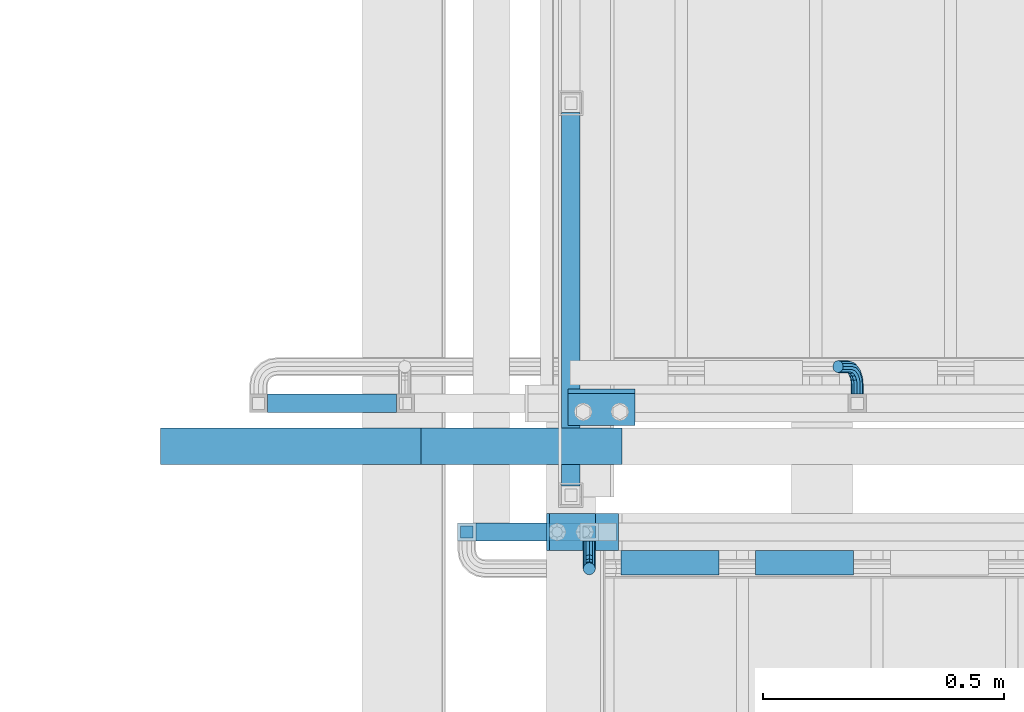
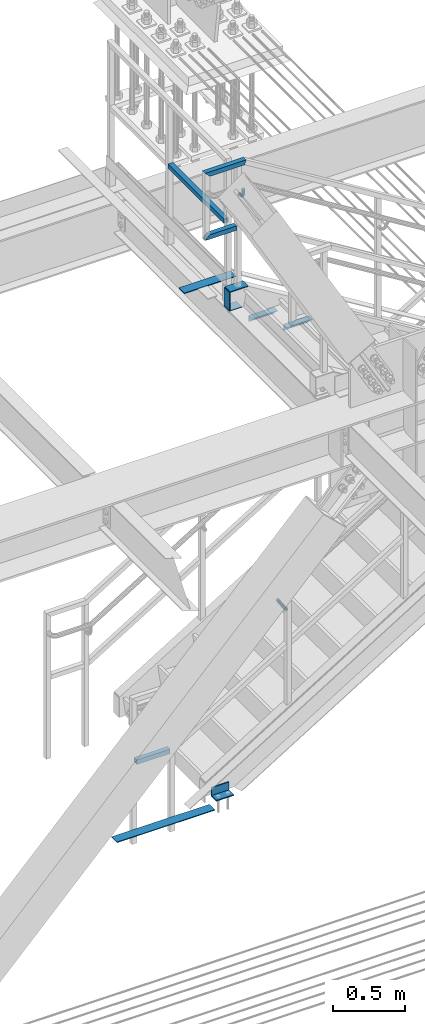
# One storey, part 2584 of 3843: 13 beams, 1 member, 7 elements without a shape of their own.
"""IFC2X3 building model written with IfcOpenShell, lengths in millimetres."""

from ifc_helpers import new_model, si_unit, frame, origin_with_axes, place, context, subcontext, project, spatial, faceted_brep, material, type_object, element, aggregate, save


model = new_model("IFC2X3")

# Units and contexts
model_context = context("Model", 3, precision=1e-05, world=origin_with_axes())
body_context = subcontext(model_context, "Body", "Model", "MODEL_VIEW")
ifc_project = project(units=[si_unit("LENGTHUNIT", "METRE", prefix="MILLI"), si_unit("AREAUNIT", "SQUARE_METRE"), si_unit("VOLUMEUNIT", "CUBIC_METRE"), si_unit("MASSUNIT", "GRAM", prefix="KILO"), si_unit("TIMEUNIT", "SECOND"), si_unit("PLANEANGLEUNIT", "RADIAN"), si_unit("SOLIDANGLEUNIT", "STERADIAN"), si_unit("THERMODYNAMICTEMPERATUREUNIT", "DEGREE_CELSIUS"), si_unit("LUMINOUSINTENSITYUNIT", "LUMEN")], contexts=[model_context])

# Site, building, storey
site_placement = place(None, origin_with_axes())
site = spatial("IfcSite", under=ifc_project, at=site_placement, CompositionType="ELEMENT")
building_placement = place(site_placement, origin_with_axes())
building = spatial("IfcBuilding", under=site, at=building_placement, Name="Undefined", CompositionType="ELEMENT")
storey_placement = place(building_placement, origin_with_axes())
storey = spatial("IfcBuildingStorey", under=building, at=storey_placement, Name="Undefined", CompositionType="ELEMENT", Elevation=0.0)

# Assembly, beam
assembly_1_placement = place(storey_placement, origin_with_axes())
assembly_1 = element("IfcElementAssembly", 1, at=assembly_1_placement, inside=storey, Name="STAIR", AssemblyPlace="NOTDEFINED", PredefinedType="RIGID_FRAME")
ifc_material_1 = material(Name="STEEL/A36")
beam_type_1 = type_object("IfcBeamType", Name="L3X3X3/8", PredefinedType="NOTDEFINED")
beam_1_placement = place(assembly_1_placement, frame((80943.4500000127, 16717.9625000001, 30518.1), z_axis=(0.0, -1.0, 0.0), x_axis=(-1.0, 0.0, 0.0)))
beam_1 = element("IfcBeam", 2, at=beam_1_placement, type_object=beam_type_1, material=ifc_material_1, Name="CLEAT", ObjectType="L3X3X3/8", context=body_context, shape_type="Brep", body=[
    faceted_brep([(0.0, 38.0999999999985, -38.0999999999985), (0.0, 38.0999999999985, 38.0999999999985), (139.699999999997, 38.0999999999985, 38.0999999999985), (139.699999999997, 38.0999999999985, -38.0999999999985), (0.0, 28.5750000000007, 38.0999999999985), (139.699999999997, 28.5750000000007, 38.0999999999985), (0.0, 28.5750000000007, -28.5750000000007), (139.699999999997, 28.5750000000007, -28.5750000000007), (0.0, -38.0999999999985, -28.5750000000007), (139.699999999997, -38.0999999999985, -28.5750000000007), (0.0, -38.0999999999985, -38.0999999999985), (139.699999999997, -38.0999999999985, -38.0999999999985)], [[[0, 1, 2, 3]], [[1, 4, 5, 2]], [[4, 6, 7, 5]], [[6, 8, 9, 7]], [[8, 10, 11, 9]], [[10, 0, 3, 11]], [[5, 7, 9, 11, 3, 2]], [[10, 8, 6, 4, 1, 0]]]),
])
aggregate(assembly_1, [beam_1])

# Assembly, beams
assembly_2_placement = place(storey_placement, origin_with_axes())
assembly_2 = element("IfcElementAssembly", 3, at=assembly_2_placement, inside=storey, Name="RAIL", AssemblyPlace="NOTDEFINED", PredefinedType="RIGID_FRAME")
ifc_material_2 = material()
beam_type_2 = type_object("IfcBeamType", Name="HSS1-1/2X1-1/2X1/4", PredefinedType="NOTDEFINED")
beam_2_placement = place(assembly_2_placement, frame((80829.1500007652, 16459.2, 35483.8), z_axis=(0.0, 0.0, 1.0), x_axis=(-1.0, 0.0, 0.0)))
beam_2 = element("IfcBeam", 4, at=beam_2_placement, type_object=beam_type_2, material=ifc_material_2, Name="RAIL", ObjectType="HSS1-1/2X1-1/2X1/4", context=body_context, shape_type="Brep", body=[
    faceted_brep([(0.0, 12.6999993299978, -12.6999993300014), (0.0, -12.6999993299978, -12.6999993300014), (247.650000111418, -12.6999993300014, -12.6999993299978), (247.650000111418, 12.6999993300014, -12.6999993299978), (0.0, -12.6999993299978, 12.6999993300014), (222.250001451423, -12.6999993300014, 12.6999993299978), (0.0, 12.6999993299978, 12.6999993300014), (222.250001451423, 12.6999993300014, 12.6999993299978), (0.0, 19.0500000000029, -19.0499999999993), (0.0, 19.0499992350015, 19.0499992350015), (215.900001546412, 19.0499992350015, 19.0499992350015), (254.000000016429, 19.0499992350015, -19.0499992350015), (0.0, -19.0499992350015, 19.0499992350015), (215.900001546412, -19.0499992350015, 19.0499992350015), (0.0, -19.0499992350015, -19.0499992350015), (254.000000016429, -19.0499992350015, -19.0499992350015)], [[[0, 1, 2, 3]], [[1, 4, 5, 2]], [[4, 6, 7, 5]], [[6, 0, 3, 7]], [[8, 9, 10, 11]], [[9, 12, 13, 10]], [[12, 14, 15, 13]], [[14, 8, 11, 15]], [[13, 15, 11, 10], [5, 7, 3, 2]], [[14, 12, 9, 8], [6, 4, 1, 0]]]),
])
beam_3_placement = place(assembly_2_placement, frame((80594.2000000002, 16459.2, 36017.2), z_axis=(0.0, 0.0, -1.0), x_axis=(1.0, 0.0, 0.0)))
beam_3 = element("IfcBeam", 5, at=beam_3_placement, type_object=beam_type_2, material=ifc_material_2, Name="RAIL", ObjectType="HSS1-1/2X1-1/2X1/4", context=body_context, shape_type="Brep", body=[
    faceted_brep([(-12.6999993309546, 12.6999993299978, -12.6999993299978), (-12.6999993309546, -12.6999993299978, -12.6999993299978), (308.394635558259, -12.6999993300014, -12.6999993299978), (308.394635558259, 12.6999993300014, -12.6999993299978), (12.6999993290483, -12.6999993299978, 12.6999993299978), (301.205364309426, -12.6999993300014, 12.6999993299978), (12.6999993290483, 12.6999993299978, 12.6999993299978), (301.205364309426, 12.6999993300014, 12.6999993299978), (-19.0499992359546, 19.0499992350015, -19.0499992350015), (19.0499992350015, 19.0499992350015, 19.0499992350015), (299.408046429278, 19.0499992350015, 19.0499992350015), (310.191953438392, 19.0499992350015, -19.0499992350015), (19.0499992350015, -19.0499992350015, 19.0499992350015), (299.408046429278, -19.0499992350015, 19.0499992350015), (-19.0499992359546, -19.0499992350015, -19.0499992350015), (310.191953438392, -19.0499992350015, -19.0499992350015)], [[[0, 1, 2, 3]], [[1, 4, 5, 2]], [[4, 6, 7, 5]], [[6, 0, 3, 7]], [[8, 9, 10, 11]], [[9, 12, 13, 10]], [[12, 14, 15, 13]], [[14, 8, 11, 15]], [[13, 15, 11, 10], [5, 7, 3, 2]], [[14, 12, 9, 8], [6, 4, 1, 0]]]),
])

# Assembly, beam
assembly_3_placement = place(storey_placement, origin_with_axes())
assembly_3 = element("IfcElementAssembly", 6, at=assembly_3_placement, inside=storey, Name="RAIL", AssemblyPlace="NOTDEFINED", PredefinedType="RIGID_FRAME")
beam_4_placement = place(assembly_3_placement, frame((80810.1, 17348.2, 35483.8), z_axis=(0.0, 0.0, 1.0), x_axis=(0.0, -1.0, 0.0)))
beam_4 = element("IfcBeam", 7, at=beam_4_placement, type_object=beam_type_2, material=ifc_material_2, Name="RAIL", ObjectType="HSS1-1/2X1-1/2X1/4", context=body_context, shape_type="Brep", body=[
    faceted_brep([(19.0499992350015, -19.0499992350015, -19.0499992350015), (19.0499992350015, -19.0499992350015, 19.0499992350015), (19.0499992350015, 19.0499992350015, 19.0499992350015), (19.0499992350015, 19.0499992350015, -19.0499992350015), (19.0499992350015, 12.6999993299978, 12.6999993299978), (19.0499992350015, -12.6999993299978, 12.6999993299978), (19.0499992350015, -12.6999993299978, -12.6999993299978), (19.0499992350015, 12.6999993299978, -12.6999993299978), (793.749999999996, 19.0499992349942, -19.0499992350015), (793.749999999996, -19.0499992349942, -19.0499992350015), (793.749999999996, -19.0499992349942, 19.0499992350015), (793.749999999996, 19.0499992349942, 19.0499992350015), (793.749999999996, -12.6999993299978, 12.6999993299978), (793.749999999996, 12.6999993299978, 12.6999993299978), (793.749999999996, 12.6999993299978, -12.6999993299978), (793.749999999996, -12.6999993299978, -12.6999993299978)], [[[0, 1, 2, 3], [4, 5, 6, 7]], [[8, 9, 0, 3]], [[9, 10, 1, 0]], [[10, 11, 2, 1]], [[11, 8, 3, 2]], [[10, 9, 8, 11], [12, 13, 14, 15]], [[13, 12, 5, 4]], [[14, 13, 4, 7]], [[15, 14, 7, 6]], [[12, 15, 6, 5]]]),
])
aggregate(assembly_3, [beam_4])

assembly_4_placement = place(storey_placement, origin_with_axes())
assembly_4 = element("IfcElementAssembly", 8, at=assembly_4_placement, inside=storey, Name="RAIL", AssemblyPlace="NOTDEFINED", PredefinedType="RIGID_FRAME")
beam_5_placement = place(assembly_4_placement, frame((80162.3999999997, 16725.9, 31013.3999999999), z_axis=(0.0, 0.0, 1.0), x_axis=(1.0, 0.0, 0.0)))
beam_5 = element("IfcBeam", 9, at=beam_5_placement, type_object=beam_type_2, material=ifc_material_2, Name="RAIL", ObjectType="HSS1-1/2X1-1/2X1/4", context=body_context, shape_type="Brep", body=[
    faceted_brep([(285.750000765285, -19.0499992350015, 19.0499992350015), (285.750000765285, -19.0499992350015, -19.0499992350015), (285.750000765285, 19.0499992350015, -19.0499992350015), (285.750000765285, 19.0499992350015, 19.0499992350015), (285.750000765009, -12.6999993300014, 12.6999993299978), (285.750000765009, 12.6999993300014, 12.6999993299978), (285.750000765009, 12.6999993300014, -12.6999993299978), (285.750000765009, -12.6999993300014, -12.6999993299978), (19.0499992350015, 19.0499992350015, -19.0499992350015), (19.0499992350015, 19.0499992350015, 19.0499992350015), (19.0499992350015, -19.0499992350015, 19.0499992350015), (19.0499992350015, -19.0499992350015, -19.0499992350015), (19.0499992350015, 12.6999993299978, 12.6999993299978), (19.0499992350015, -12.6999993299978, 12.6999993299978), (19.0499992350015, -12.6999993299978, -12.6999993299978), (19.0499992350015, 12.6999993299978, -12.6999993299978)], [[[0, 1, 2, 3], [4, 5, 6, 7]], [[8, 9, 3, 2]], [[9, 10, 0, 3]], [[10, 11, 1, 0]], [[11, 8, 2, 1]], [[11, 10, 9, 8], [12, 13, 14, 15]], [[14, 13, 4, 7]], [[15, 14, 7, 6]], [[12, 15, 6, 5]], [[13, 12, 5, 4]]]),
])

# Assembly, beams
assembly_5_placement = place(storey_placement, origin_with_axes())
assembly_5 = element("IfcElementAssembly", 10, at=assembly_5_placement, inside=storey, Name="STAIR", AssemblyPlace="NOTDEFINED", PredefinedType="RIGID_FRAME")
beam_type_3 = type_object("IfcBeamType", PredefinedType="NOTDEFINED")
beam_6_placement = place(assembly_5_placement, frame((80759.299999998, 16459.2000000053, 34813.875), z_axis=(0.0, 1.0, 0.0), x_axis=(1.0, 0.0, 0.0)))
beam_6 = element("IfcBeam", 11, at=beam_6_placement, type_object=beam_type_3, material=ifc_material_1, Name="PLATE", context=body_context, shape_type="Brep", body=[
    faceted_brep([(0.0, 3.17500000000291, -38.0999999999985), (0.0, 3.17500000000291, 38.0999999999985), (101.60000000002, 3.17500000000291, 38.0999999999985), (101.60000000002, 3.17500000000291, -38.0999999999985), (0.0, -3.17500000000291, 38.0999999999985), (101.60000000002, -3.17500000000291, 38.0999999999985), (0.0, -3.17500000000291, -38.0999999999985), (101.60000000002, -3.17500000000291, -38.0999999999985)], [[[0, 1, 2, 3]], [[1, 4, 5, 2]], [[4, 6, 7, 5]], [[6, 0, 3, 7]], [[5, 7, 3, 2]], [[6, 4, 1, 0]]]),
])
ifc_material_3 = material(Name="STEEL/A572-50")
beam_7_placement = place(assembly_5_placement, frame((80908.4302402225, 16459.1999999992, 34972.625), z_axis=(0.0, -1.0, 0.0), x_axis=(-1.0, 0.0, 0.0)))
beam_7 = element("IfcBeam", 12, at=beam_7_placement, type_object=beam_type_3, material=ifc_material_3, Name="PLATE", context=body_context, shape_type="Brep", body=[
    faceted_brep([(0.0, 3.17500000000291, -38.0999999999985), (0.0, 3.17500000000291, 38.0999999999985), (142.780240222812, 3.17500000000291, 38.1000000000004), (142.780240222812, 3.17500000000291, -38.1000000000004), (0.0, -3.17500000000291, 38.0999999999985), (142.780240222812, -3.17500000000291, 38.1000000000004), (0.0, -3.17500000000291, -38.0999999999985), (142.780240222812, -3.17500000000291, -38.1000000000004)], [[[0, 1, 2, 3]], [[1, 4, 5, 2]], [[4, 6, 7, 5]], [[6, 0, 3, 7]], [[5, 7, 3, 2]], [[6, 4, 1, 0]]]),
])
beam_8_placement = place(assembly_5_placement, frame((80762.475, 16459.2000000001, 34969.4500000002), z_axis=(0.0, -1.0, 0.0), x_axis=(0.0, 0.0, -1.0)))
beam_8 = element("IfcBeam", 13, at=beam_8_placement, type_object=beam_type_3, material=ifc_material_3, Name="PLATE", context=body_context, shape_type="Brep", body=[
    faceted_brep([(0.0, -3.17500000000291, -38.0999999999985), (0.0, -3.17500000000291, 38.0999999999985), (0.0, 3.17500000000291, 38.0999999999985), (0.0, 3.17500000000291, -38.0999999999985), (152.400000000009, -3.17500000000291, 38.0999999999985), (152.400000000009, 3.17500000000291, 38.0999999999985), (152.400000000009, 3.17500000000291, -38.0999999999985), (152.400000000009, -3.17500000000291, -38.0999999999985)], [[[0, 1, 2, 3]], [[2, 1, 4, 5]], [[3, 2, 5, 6]], [[0, 3, 6, 7]], [[1, 0, 7, 4]], [[4, 7, 6, 5]]]),
])

# Assembly, beam
assembly_6_placement = place(storey_placement, origin_with_axes())
assembly_6 = element("IfcElementAssembly", 14, at=assembly_6_placement, inside=storey, Name="ref.", AssemblyPlace="NOTDEFINED", PredefinedType="RIGID_FRAME")
ifc_material_4 = material(Name="STEEL/Steel_Undefined")
beam_9_placement = place(assembly_6_placement, frame((79959.2, 16637.0, 30476.825), z_axis=(0.0, 1.0, 0.0), x_axis=(1.0, 0.0, 0.0)))
beam_9 = element("IfcBeam", 15, at=beam_9_placement, type_object=beam_type_3, material=ifc_material_4, Name="ref.", context=body_context, shape_type="Brep", body=[
    faceted_brep([(0.0, 3.17500000000291, -38.0999999999985), (0.0, 3.17500000000291, 38.0999999999985), (787.400000000009, 3.17499999999927, 38.0999999999985), (787.400000000009, 3.17499999999927, -38.0999999999985), (0.0, -3.17500000000291, 38.0999999999985), (787.400000000009, -3.17499999999927, 38.0999999999985), (0.0, -3.17500000000291, -38.0999999999985), (787.400000000009, -3.17499999999927, -38.0999999999985)], [[[0, 1, 2, 3]], [[1, 4, 5, 2]], [[4, 6, 7, 5]], [[6, 0, 3, 7]], [[5, 7, 3, 2]], [[6, 4, 1, 0]]]),
])
aggregate(assembly_6, [beam_9])

# Beam
beam_type_4 = type_object("IfcBeamType", Name="L2X2X3/16", PredefinedType="NOTDEFINED")
beam_10_placement = place(assembly_5_placement, frame((80913.6859969632, 16395.6999999086, 34699.0865384572), z_axis=(0.0, -1.0, 0.0), x_axis=(1.0, 0.0, 0.0)))
beam_10 = element("IfcBeam", 16, at=beam_10_placement, type_object=beam_type_4, material=ifc_material_1, Name="ANGLE", ObjectType="L2X2X3/16", context=body_context, shape_type="Brep", body=[
    faceted_brep([(0.0, 25.4000000000015, -25.4000000000015), (0.0, 25.4000000000015, 25.4000000000015), (203.199999999997, 25.4000000000015, 25.4000000000015), (203.199999999997, 25.4000000000015, -25.4000000000015), (0.0, 20.6375000000007, 25.4000000000015), (203.199999999997, 20.6375000000007, 25.4000000000015), (0.0, 20.6375000000007, -20.6375000000007), (203.199999999997, 20.6375000000007, -20.6375000000007), (0.0, -25.4000000000015, -20.6375000000007), (203.199999999997, -25.4000000000015, -20.6375000000007), (0.0, -25.4000000000015, -25.4000000000015), (203.199999999997, -25.4000000000015, -25.4000000000015)], [[[0, 1, 2, 3]], [[1, 4, 5, 2]], [[4, 6, 7, 5]], [[6, 8, 9, 7]], [[8, 10, 11, 9]], [[10, 0, 3, 11]], [[5, 7, 9, 11, 3, 2]], [[10, 8, 6, 4, 1, 0]]]),
])

beam_11_placement = place(assembly_5_placement, frame((81193.0859969491, 16395.700000067, 34527.1480769223), z_axis=(0.0, -1.0, 0.0), x_axis=(1.0, 0.0, 0.0)))
beam_11 = element("IfcBeam", 17, at=beam_11_placement, type_object=beam_type_4, material=ifc_material_1, Name="ANGLE", ObjectType="L2X2X3/16", context=body_context, shape_type="Brep", body=[
    faceted_brep([(0.0, 25.4000000000015, -25.4000000000015), (0.0, 25.4000000000015, 25.4000000000015), (203.199999999997, 25.4000000000015, 25.4000000000015), (203.199999999997, 25.4000000000015, -25.4000000000015), (0.0, 20.6375000000007, 25.4000000000015), (203.199999999997, 20.6375000000007, 25.4000000000015), (0.0, 20.6375000000007, -20.6375000000007), (203.199999999997, 20.6375000000007, -20.6375000000007), (0.0, -25.4000000000015, -20.6375000000007), (203.199999999997, -25.4000000000015, -20.6375000000007), (0.0, -25.4000000000015, -25.4000000000015), (203.199999999997, -25.4000000000015, -25.4000000000015)], [[[0, 1, 2, 3]], [[1, 4, 5, 2]], [[4, 6, 7, 5]], [[6, 8, 9, 7]], [[8, 10, 11, 9]], [[10, 0, 3, 11]], [[5, 7, 9, 11, 3, 2]], [[10, 8, 6, 4, 1, 0]]]),
])

aggregate(assembly_5, [beam_10, beam_6, beam_7, beam_8, beam_11])

beam_type_5 = type_object("IfcBeamType", PredefinedType="NOTDEFINED")
beam_12_placement = place(assembly_2_placement, frame((80848.2000000003, 16440.15, 35769.5574971194), z_axis=(-1.0, 0.0, 0.0), x_axis=(0.0, -1.0, 0.0)))
beam_12 = element("IfcBeam", 18, at=beam_12_placement, type_object=beam_type_5, material=ifc_material_1, Name="BRACKET ARM", context=body_context, shape_type="Brep", body=[
    faceted_brep([(0.0, -12.6999999999971, 0.0), (0.0, -10.9985226280696, -6.34999999999854), (19.0500015258731, -10.9985226280623, -6.34999999999854), (19.0500015258731, -12.6999999999971, -6.33008312433958e-10), (0.0, -6.35000000000582, -10.9985226280623), (19.0500015258731, -6.34999999999854, -10.9985226280623), (0.0, 0.0, -12.6999999999971), (19.0500015258731, 0.0, -12.6999999999971), (0.0, 6.35000000000582, -10.9985226280623), (19.0500015258731, 6.34999999999854, -10.9985226280623), (0.0, 10.9985226280696, -6.34999999999854), (19.0500015258731, 10.9985226280623, -6.34999999999854), (0.0, 12.6999999999971, 0.0), (19.0500015258731, 12.6999999999971, 0.0), (0.0, 10.9985226280696, 6.34999999999854), (19.0500015258731, 10.9985226280623, 6.34999999999854), (0.0, 6.35000000000582, 10.9985226280623), (19.0500015258731, 6.34999999999854, 10.9985226280623), (0.0, 0.0, 12.6999999999971), (19.0500015258731, 0.0, 12.6999999999971), (0.0, -6.35000000000582, 10.9985226280623), (19.0500015258731, -6.34999999999854, 10.9985226280623), (0.0, -10.9985226280696, 6.34999999999854), (19.0500015258731, -10.9985226280623, 6.34999999999854), (38.4903193060891, -8.8330803677236, -3.34694050252438e-10), (37.8391921052389, -7.26112024908798, 6.34999999974389), (36.0602795104642, -2.96644533684594, 10.9985226280041), (33.6302397149266, 2.90018969451194, 12.7000000002226), (31.2001999194181, 8.76682472604443, 10.9985226285644), (29.4212873247307, 13.061499638774, 6.35000000070431), (28.7701601240115, 14.6334597580644, 7.78527464717627e-10), (29.4212873248762, 13.0614996394288, -6.34999999929278), (31.2001999196509, 8.76682472718676, -10.9985226275603), (33.6302397151885, 2.90018969582889, -12.6999999997788), (36.0602795106824, -2.96644533571089, -10.9985226281206), (37.8391921053699, -7.26112024843314, -6.35000000026048), (53.7678987435793, 3.38210125690239, -6.3499999994383), (54.9710249311902, 2.17897506880399, 5.0931703299284e-10), (50.4808968708676, 6.66910312997061, -10.9985226273784), (45.9907688103704, 11.1592311906061, -12.6999999991458), (41.5006407498004, 15.6493592510378, -10.9985226270364), (38.213638876914, 18.9363611235749, -6.34999999884167), (37.0105126890558, 20.1394873109457, 1.20053300634027e-09), (38.2136388766667, 18.9363611228473, 6.35000000115542), (41.5006407493784, 15.6493592497718, 10.9985226290883), (45.9907688098756, 11.1592311891436, 12.7000000008557), (50.4808968704456, 6.66910312870459, 10.9985226287463), (53.7678987433319, 3.38210125617479, 6.35000000055879), (64.4111202489148, 19.3108078951118, -6.34999999821594), (65.9830803677178, 18.6596806939051, 1.77533365786076e-09), (60.1164453365491, 21.0897204901557, -10.9985226262725), (54.2498103051475, 23.5197602857806, -12.6999999981927), (48.3831752736587, 25.9498000811873, -10.9985226262434), (44.0885003610601, 27.7287126756128, -6.34999999817228), (42.516540241937, 28.3798398759754, 1.83354131877422e-09), (44.08850036074, 27.7287126747688, 6.35000000183209), (48.3831752731057, 25.9498000797321, 10.9985226298813), (54.2498103045073, 23.5197602840999, 12.7000000018088), (60.1164453359961, 21.0897204886933, 10.9985226298522), (64.4111202485947, 19.3108078942678, 6.35000000178115), (68.1485226282239, 38.0999984746086, -6.3499999967753), (69.8499999999913, 38.0999984741211, 2.92493496090174e-09), (63.500000000291, 38.0999984749651, -10.9985226249628), (57.1500000003434, 38.0999984750961, -12.6999999970722), (50.8000000002939, 38.0999984749651, -10.998522625312), (46.1514773720992, 38.0999984746086, -6.34999999737192), (44.4499999999971, 38.0999984741211, 2.58296495303512e-09), (46.1514773717645, 38.0999984736336, 6.35000000262517), (50.7999999996973, 38.0999984732771, 10.9985226308127), (57.1499999996449, 38.0999984731461, 12.700000002922), (63.4999999996944, 38.0999984732771, 10.9985226311619), (68.1485226278892, 38.0999984736336, 6.35000000322179), (68.1485226280638, 76.2000000002372, -6.34999999414867), (69.8499999999913, 76.199999999757, 5.84986992180347e-09), (63.5, 76.200000000601, -10.9985226222125), (57.1499999999942, 76.2000000007247, -12.6999999941472), (50.7999999999884, 76.200000000601, -10.9985226222125), (46.1514773719246, 76.2000000002372, -6.34999999414867), (44.4499999999971, 76.199999999757, 5.84986992180347e-09), (46.1514773719246, 76.1999999992695, 6.35000000584841), (50.7999999999884, 76.1999999989057, 10.9985226339122), (57.1499999999942, 76.199999998782, 12.700000005847), (63.5, 76.1999999989057, 10.9985226339122), (68.1485226280638, 76.1999999992695, 6.35000000584841)], [[[0, 1, 2, 3]], [[1, 4, 5, 2]], [[4, 6, 7, 5]], [[6, 8, 9, 7]], [[8, 10, 11, 9]], [[10, 12, 13, 11]], [[12, 14, 15, 13]], [[14, 16, 17, 15]], [[16, 18, 19, 17]], [[18, 20, 21, 19]], [[20, 22, 23, 21]], [[22, 0, 3, 23]], [[22, 20, 18, 16, 14, 12, 10, 8, 6, 4, 1, 0]], [[23, 3, 24, 25]], [[21, 23, 25, 26]], [[19, 21, 26, 27]], [[17, 19, 27, 28]], [[15, 17, 28, 29]], [[13, 15, 29, 30]], [[11, 13, 30, 31]], [[9, 11, 31, 32]], [[7, 9, 32, 33]], [[5, 7, 33, 34]], [[2, 5, 34, 35]], [[3, 2, 35, 24]], [[35, 36, 37, 24]], [[34, 38, 36, 35]], [[33, 39, 38, 34]], [[32, 40, 39, 33]], [[31, 41, 40, 32]], [[30, 42, 41, 31]], [[29, 43, 42, 30]], [[28, 44, 43, 29]], [[27, 45, 44, 28]], [[26, 46, 45, 27]], [[25, 47, 46, 26]], [[24, 37, 47, 25]], [[36, 48, 49, 37]], [[38, 50, 48, 36]], [[39, 51, 50, 38]], [[40, 52, 51, 39]], [[41, 53, 52, 40]], [[42, 54, 53, 41]], [[43, 55, 54, 42]], [[44, 56, 55, 43]], [[45, 57, 56, 44]], [[46, 58, 57, 45]], [[47, 59, 58, 46]], [[37, 49, 59, 47]], [[48, 60, 61, 49]], [[50, 62, 60, 48]], [[51, 63, 62, 50]], [[52, 64, 63, 51]], [[53, 65, 64, 52]], [[54, 66, 65, 53]], [[55, 67, 66, 54]], [[56, 68, 67, 55]], [[57, 69, 68, 56]], [[58, 70, 69, 57]], [[59, 71, 70, 58]], [[49, 61, 71, 59]], [[61, 60, 72, 73]], [[60, 62, 74, 72]], [[62, 63, 75, 74]], [[63, 64, 76, 75]], [[64, 65, 77, 76]], [[65, 66, 78, 77]], [[66, 67, 79, 78]], [[67, 68, 80, 79]], [[68, 69, 81, 80]], [[69, 70, 82, 81]], [[70, 71, 83, 82]], [[71, 61, 73, 83]], [[74, 75, 76, 77, 78, 79, 80, 81, 82, 83, 73, 72]]]),
])

aggregate(assembly_2, [beam_2, beam_3, beam_12])

beam_13_placement = place(assembly_4_placement, frame((81404.0372504223, 16744.95, 31859.0746041877), z_axis=(0.851658316635872, 0.0, 0.524097425775926), x_axis=(0.0, 1.0, 0.0)))
beam_13 = element("IfcBeam", 19, at=beam_13_placement, type_object=beam_type_5, material=ifc_material_1, Name="BRACKET ARM", context=body_context, shape_type="Brep", body=[
    faceted_brep([(0.0, -12.6999999999971, 0.0), (0.0, -10.9985226280696, -6.34999999999854), (19.0500015258731, -10.9985226280623, -6.34999999999854), (19.0500015258731, -12.6999999999971, -6.33008312433958e-10), (0.0, -6.35000000000582, -10.9985226280623), (19.0500015258731, -6.34999999999854, -10.9985226280623), (0.0, 0.0, -12.6999999999971), (19.0500015258731, 0.0, -12.6999999999971), (0.0, 6.35000000000582, -10.9985226280623), (19.0500015258731, 6.34999999999854, -10.9985226280623), (0.0, 10.9985226280696, -6.34999999999854), (19.0500015258731, 10.9985226280623, -6.34999999999854), (0.0, 12.6999999999971, 0.0), (19.0500015258731, 12.6999999999971, 0.0), (0.0, 10.9985226280696, 6.34999999999854), (19.0500015258731, 10.9985226280623, 6.34999999999854), (0.0, 6.35000000000582, 10.9985226280623), (19.0500015258731, 6.34999999999854, 10.9985226280623), (0.0, 0.0, 12.6999999999971), (19.0500015258731, 0.0, 12.6999999999971), (0.0, -6.35000000000582, 10.9985226280623), (19.0500015258731, -6.34999999999854, 10.9985226280623), (0.0, -10.9985226280696, 6.34999999999854), (19.0500015258731, -10.9985226280623, 6.34999999999854), (38.4903193060891, -8.8330803677236, -3.34694050252438e-10), (37.8391921052389, -7.26112024908798, 6.34999999974389), (36.0602795104642, -2.96644533684594, 10.9985226280041), (33.6302397149266, 2.90018969451194, 12.7000000002226), (31.2001999194181, 8.76682472604443, 10.9985226285644), (29.4212873247307, 13.061499638774, 6.35000000070431), (28.7701601240115, 14.6334597580644, 7.78527464717627e-10), (29.4212873248762, 13.0614996394288, -6.34999999929278), (31.2001999196509, 8.76682472718676, -10.9985226275603), (33.6302397151885, 2.90018969582889, -12.6999999997788), (36.0602795106824, -2.96644533571089, -10.9985226281206), (37.8391921053699, -7.26112024843314, -6.35000000026048), (53.7678987435793, 3.38210125690239, -6.3499999994383), (54.9710249311902, 2.17897506880399, 5.0931703299284e-10), (50.4808968708676, 6.66910312997061, -10.9985226273784), (45.9907688103704, 11.1592311906061, -12.6999999991458), (41.5006407498004, 15.6493592510378, -10.9985226270364), (38.213638876914, 18.9363611235749, -6.34999999884167), (37.0105126890558, 20.1394873109457, 1.20053300634027e-09), (38.2136388766667, 18.9363611228473, 6.35000000115542), (41.5006407493784, 15.6493592497718, 10.9985226290883), (45.9907688098756, 11.1592311891436, 12.7000000008557), (50.4808968704456, 6.66910312870459, 10.9985226287463), (53.7678987433319, 3.38210125617479, 6.35000000055879), (64.4111202489148, 19.3108078951118, -6.34999999821594), (65.9830803677178, 18.6596806939051, 1.77533365786076e-09), (60.1164453365491, 21.0897204901557, -10.9985226262725), (54.2498103051475, 23.5197602857806, -12.6999999981927), (48.3831752736587, 25.9498000811873, -10.9985226262434), (44.0885003610601, 27.7287126756128, -6.34999999817228), (42.516540241937, 28.3798398759754, 1.83354131877422e-09), (44.08850036074, 27.7287126747688, 6.35000000183209), (48.3831752731057, 25.9498000797321, 10.9985226298813), (54.2498103045073, 23.5197602840999, 12.7000000018088), (60.1164453359961, 21.0897204886933, 10.9985226298522), (64.4111202485947, 19.3108078942678, 6.35000000178115), (68.1485226282239, 38.0999984746086, -6.3499999967753), (69.8499999999913, 38.0999984741211, 2.92493496090174e-09), (63.500000000291, 38.0999984749651, -10.9985226249628), (57.1500000003434, 38.0999984750961, -12.6999999970722), (50.8000000002939, 38.0999984749651, -10.998522625312), (46.1514773720992, 38.0999984746086, -6.34999999737192), (44.4499999999971, 38.0999984741211, 2.58296495303512e-09), (46.1514773717645, 38.0999984736336, 6.35000000262517), (50.7999999996973, 38.0999984732771, 10.9985226308127), (57.1499999996449, 38.0999984731461, 12.700000002922), (63.4999999996944, 38.0999984732771, 10.9985226311619), (68.1485226278892, 38.0999984736336, 6.35000000322179), (68.1485226280638, 76.2000000002372, -6.34999999414867), (69.8499999999913, 76.199999999757, 5.84986992180347e-09), (63.5, 76.200000000601, -10.9985226222125), (57.1499999999942, 76.2000000007247, -12.6999999941472), (50.7999999999884, 76.200000000601, -10.9985226222125), (46.1514773719246, 76.2000000002372, -6.34999999414867), (44.4499999999971, 76.199999999757, 5.84986992180347e-09), (46.1514773719246, 76.1999999992695, 6.35000000584841), (50.7999999999884, 76.1999999989057, 10.9985226339122), (57.1499999999942, 76.199999998782, 12.700000005847), (63.5, 76.1999999989057, 10.9985226339122), (68.1485226280638, 76.1999999992695, 6.35000000584841)], [[[0, 1, 2, 3]], [[1, 4, 5, 2]], [[4, 6, 7, 5]], [[6, 8, 9, 7]], [[8, 10, 11, 9]], [[10, 12, 13, 11]], [[12, 14, 15, 13]], [[14, 16, 17, 15]], [[16, 18, 19, 17]], [[18, 20, 21, 19]], [[20, 22, 23, 21]], [[22, 0, 3, 23]], [[22, 20, 18, 16, 14, 12, 10, 8, 6, 4, 1, 0]], [[23, 3, 24, 25]], [[21, 23, 25, 26]], [[19, 21, 26, 27]], [[17, 19, 27, 28]], [[15, 17, 28, 29]], [[13, 15, 29, 30]], [[11, 13, 30, 31]], [[9, 11, 31, 32]], [[7, 9, 32, 33]], [[5, 7, 33, 34]], [[2, 5, 34, 35]], [[3, 2, 35, 24]], [[35, 36, 37, 24]], [[34, 38, 36, 35]], [[33, 39, 38, 34]], [[32, 40, 39, 33]], [[31, 41, 40, 32]], [[30, 42, 41, 31]], [[29, 43, 42, 30]], [[28, 44, 43, 29]], [[27, 45, 44, 28]], [[26, 46, 45, 27]], [[25, 47, 46, 26]], [[24, 37, 47, 25]], [[36, 48, 49, 37]], [[38, 50, 48, 36]], [[39, 51, 50, 38]], [[40, 52, 51, 39]], [[41, 53, 52, 40]], [[42, 54, 53, 41]], [[43, 55, 54, 42]], [[44, 56, 55, 43]], [[45, 57, 56, 44]], [[46, 58, 57, 45]], [[47, 59, 58, 46]], [[37, 49, 59, 47]], [[48, 60, 61, 49]], [[50, 62, 60, 48]], [[51, 63, 62, 50]], [[52, 64, 63, 51]], [[53, 65, 64, 52]], [[54, 66, 65, 53]], [[55, 67, 66, 54]], [[56, 68, 67, 55]], [[57, 69, 68, 56]], [[58, 70, 69, 57]], [[59, 71, 70, 58]], [[49, 61, 71, 59]], [[61, 60, 72, 73]], [[60, 62, 74, 72]], [[62, 63, 75, 74]], [[63, 64, 76, 75]], [[64, 65, 77, 76]], [[65, 66, 78, 77]], [[66, 67, 79, 78]], [[67, 68, 80, 79]], [[68, 69, 81, 80]], [[69, 70, 82, 81]], [[70, 71, 83, 82]], [[71, 61, 73, 83]], [[74, 75, 76, 77, 78, 79, 80, 81, 82, 83, 73, 72]]]),
])

aggregate(assembly_4, [beam_13, beam_5])

# Assembly, member
assembly_7_placement = place(storey_placement, origin_with_axes())
assembly_7 = element("IfcElementAssembly", 20, at=assembly_7_placement, inside=storey, Name="ref.", AssemblyPlace="NOTDEFINED", PredefinedType="RIGID_FRAME")
member_type = type_object("IfcMemberType", PredefinedType="NOTDEFINED")
member_placement = place(assembly_7_placement, frame((80916.5080226874, 16637.0, 34947.225), z_axis=(0.0, -1.0, 0.0), x_axis=(-1.0, 0.0, 0.0)))
member = element("IfcMember", 21, at=member_placement, type_object=member_type, material=ifc_material_4, Name="ref.", context=body_context, shape_type="Brep", body=[
    faceted_brep([(0.0, 3.17500000000291, -38.0999999999985), (0.0, 3.17500000000291, 38.0999999999985), (417.512499999997, 3.17500000000291, 38.0999999999985), (417.512499999997, 3.17500000000291, -38.0999999999985), (0.0, -3.17500000000291, 38.0999999999985), (417.512499999997, -3.17500000000291, 38.0999999999985), (0.0, -3.17500000000291, -38.0999999999985), (417.512499999997, -3.17500000000291, -38.0999999999985)], [[[0, 1, 2, 3]], [[1, 4, 5, 2]], [[4, 6, 7, 5]], [[6, 0, 3, 7]], [[5, 7, 3, 2]], [[6, 4, 1, 0]]]),
])
aggregate(assembly_7, [member])

save(model, "model.ifc")
